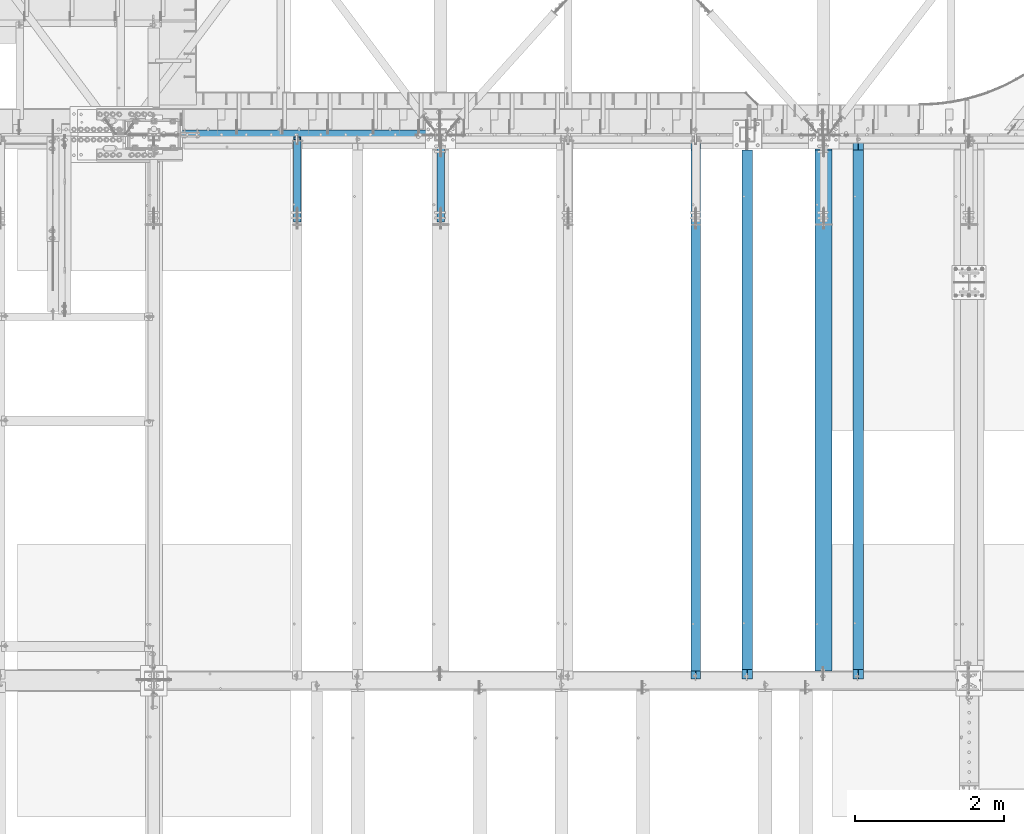
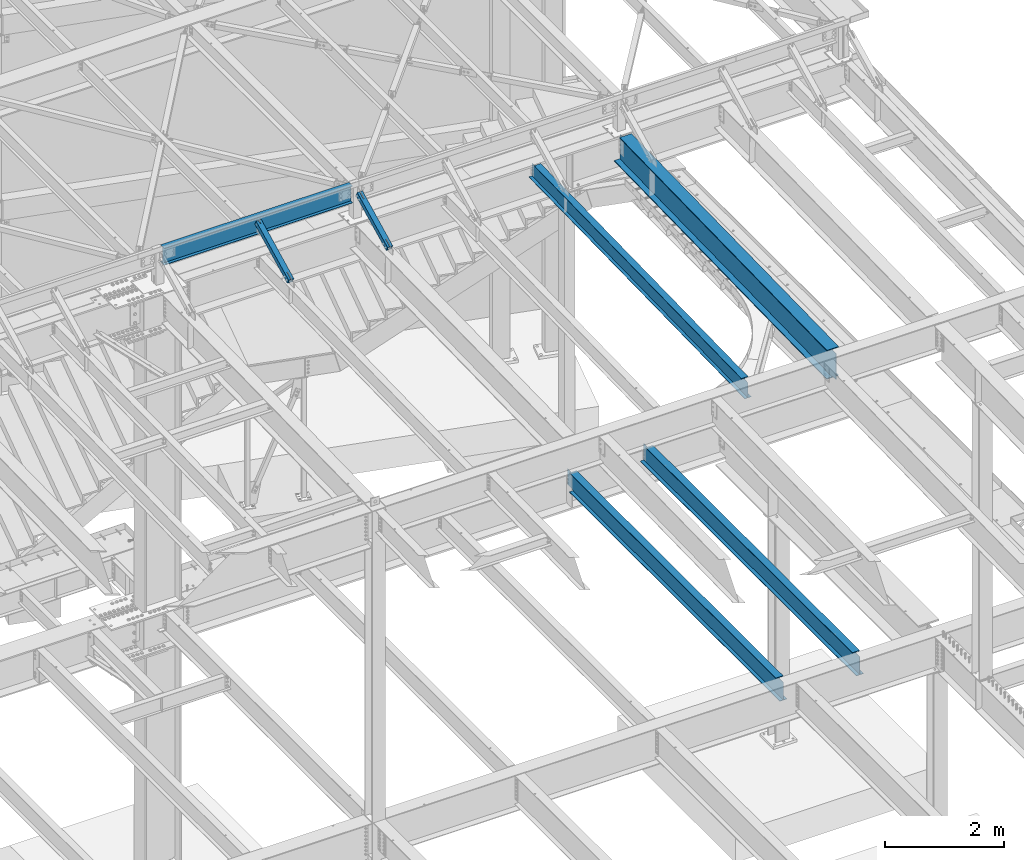
# One storey, part 1161 of 1763: 5 beams, 2 members, 7 elements without a shape of their own.
"""IFC2X3 building model written with IfcOpenShell, lengths in millimetres."""

import ifcopenshell
import ifcopenshell.guid

model = None  # the IFC model being written
_history = None  # IfcOwnerHistory: only IFC2X3 demands one
_inside = {}  # id of a spatial element -> (the spatial element, [elements in it])
_under = {}  # id of a project, library or spatial element -> (it, [spatial elements below it])
_declared = {}  # id of a project -> (the project, [libraries it declares])
_typed = {}  # id of a type object -> (the type object, [elements of that type])
_made_of = {}  # id of a material, layer set ... -> (it, [elements and type objects made of it])


def new_model(schema):
    """Start an empty IFC model of exactly this schema.

    Asked for "IFC4X3", IfcOpenShell would pick the latest addendum, in which some entities
    have other attributes; the version numbers below select the first issue.
    IFC2X3 requires an IfcOwnerHistory on every rooted entity: one is made here for all.
    """
    global model, _history
    if schema == "IFC4X3":
        model = ifcopenshell.file(schema_version=(4, 3, 0, 0))
    else:
        model = ifcopenshell.file(schema=schema)
    _inside.clear()
    _under.clear()
    _declared.clear()
    _typed.clear()
    _made_of.clear()
    _history = None
    if model.schema == "IFC2X3":
        org = make("IfcOrganization", Name="unknown")
        user = make(
            "IfcPersonAndOrganization",
            ThePerson=make("IfcPerson", FamilyName="unknown"),
            TheOrganization=org,
        )
        app = make(
            "IfcApplication",
            ApplicationDeveloper=org,
            Version="unknown",
            ApplicationFullName="unknown",
            ApplicationIdentifier="unknown",
        )
        _history = make(
            "IfcOwnerHistory",
            OwningUser=user,
            OwningApplication=app,
            ChangeAction="ADDED",
            CreationDate=0,
        )
    return model


def make(cls, **values):
    """One entity of the class cls with the attributes given. An attribute that is None is left unset."""
    return model.create_entity(
        cls, **{name: value for name, value in values.items() if value is not None}
    )


def rooted(cls, **values):
    """An entity with a GlobalId (a new one), such as an element, a storey or a relation."""
    return make(cls, GlobalId=ifcopenshell.guid.new(), OwnerHistory=_history, **values)


def si_unit(unit_type, name, prefix=None):
    """IfcSIUnit, for example si_unit("LENGTHUNIT", "METRE", prefix="MILLI")."""
    return make("IfcSIUnit", UnitType=unit_type, Prefix=prefix, Name=name)


def assignment(units):
    """IfcUnitAssignment: the units of a project."""
    return None if units is None else make("IfcUnitAssignment", Units=units)


def point(xyz):
    """IfcCartesianPoint."""
    return None if xyz is None else make("IfcCartesianPoint", Coordinates=xyz)


def direction(xyz):
    """IfcDirection."""
    return None if xyz is None else make("IfcDirection", DirectionRatios=xyz)


def frame(location, z_axis=None, x_axis=None):
    """IfcAxis2Placement3D, a coordinate frame: its origin and axes. An axis left out is left unset."""
    return make(
        "IfcAxis2Placement3D",
        Location=point(location),
        Axis=direction(z_axis),
        RefDirection=direction(x_axis),
    )


def origin_with_axes():
    """The frame at (0, 0, 0) with the z axis (0, 0, 1) and the x axis (1, 0, 0) written out."""
    return frame((0.0, 0.0, 0.0), z_axis=(0.0, 0.0, 1.0), x_axis=(1.0, 0.0, 0.0))


def place(relative_to, where):
    """IfcLocalPlacement: puts the frame where relative to a parent placement (None: the world)."""
    return make(
        "IfcLocalPlacement", PlacementRelTo=relative_to, RelativePlacement=where
    )


def context(
    kind, dimensions, precision=None, world=None, true_north=None, identifier=None
):
    """IfcGeometricRepresentationContext, for example the 3D "Model" context."""
    return make(
        "IfcGeometricRepresentationContext",
        ContextIdentifier=identifier,
        ContextType=kind,
        CoordinateSpaceDimension=dimensions,
        Precision=precision,
        WorldCoordinateSystem=world,
        TrueNorth=true_north,
    )


def subcontext(parent, identifier, kind, view, scale=None):
    """IfcGeometricRepresentationSubContext, for example "Body" below "Model"."""
    return make(
        "IfcGeometricRepresentationSubContext",
        ContextIdentifier=identifier,
        ContextType=kind,
        ParentContext=parent,
        TargetScale=scale,
        TargetView=view,
    )


def project(units=None, contexts=None):
    """IfcProject with its units and contexts."""
    return rooted(
        "IfcProject",
        Name="project",
        RepresentationContexts=contexts,
        UnitsInContext=assignment(units),
    )


def spatial(cls, under=None, at=None, **own):
    """A site, building, storey or space (cls), placed at a placement, below another one or the project."""
    s = rooted(cls, ObjectPlacement=at, **own)
    if under is not None:
        _under.setdefault(under.id(), (under, []))[1].append(s)
    return s


def faces_of(points, faces, orient=None, outer=None):
    """IfcFace entities. A face is a list of loops; a loop is a list of indices into points, from 0.

    orient and outer hold one flag for each loop. By default every Orientation is true, the
    first loop of a face is its IfcFaceOuterBound and the others are IfcFaceBound.
    """
    made = []
    for i, loops in enumerate(faces):
        bounds = []
        for j, loop in enumerate(loops):
            is_outer = j == 0 if outer is None else outer[i][j]
            bounds.append(
                make(
                    "IfcFaceOuterBound" if is_outer else "IfcFaceBound",
                    Bound=make("IfcPolyLoop", Polygon=[points[k] for k in loop]),
                    Orientation=True if orient is None else orient[i][j],
                )
            )
        made.append(make("IfcFace", Bounds=bounds))
    return made


def faceted_brep(points, faces, orient=None, outer=None, voids=None):
    """IfcFacetedBrep: a solid bounded by flat faces; with voids (closed shells), ...WithVoids."""
    shared = [point(p) for p in points]
    hull = make("IfcClosedShell", CfsFaces=faces_of(shared, faces, orient, outer))
    if voids is None:
        return make("IfcFacetedBrep", Outer=hull)
    return make(
        "IfcFacetedBrepWithVoids",
        Outer=hull,
        Voids=[
            make(cls, CfsFaces=faces_of(shared, fs, o, b)) for cls, fs, o, b in voids
        ],
    )


def shape(context_of_items, identifier, shape_type, items):
    """IfcShapeRepresentation: the items that make up one representation, for example the "Body"."""
    return make(
        "IfcShapeRepresentation",
        ContextOfItems=context_of_items,
        RepresentationIdentifier=identifier,
        RepresentationType=shape_type,
        Items=items,
    )


def material(Name=None, Category=None):
    """IfcMaterial."""
    return make("IfcMaterial", Name=Name, Category=Category)


def made_of(thing, what):
    """Note that an element or type object is made of a material, layer set ...; save() writes the relation."""
    if what is not None:
        _made_of.setdefault(what.id(), (what, []))[1].append(thing)
    return thing


def type_object(cls, material=None, **own):
    """A type object (cls), such as IfcWallType, which elements share."""
    return made_of(rooted(cls, **own), material)


def element(
    cls,
    number,
    at=None,
    inside=None,
    cuts=None,
    type_object=None,
    material=None,
    context=None,
    identifier="Body",
    shape_type=None,
    held_by="IfcProductDefinitionShape",
    body=None,
    shapes=None,
    **own,
):
    """One element of the class cls, such as IfcWall. Its Tag is "e" and its number.

    at: its placement. inside: the storey or other place that contains it. cuts: it is an
    opening in that element (IfcRelVoidsElement). A single representation is given by context,
    identifier, shape_type and body (its items); several are given by shapes. held_by: the class
    of the entity that holds the representations. save() writes the other relations.
    """
    e = rooted(cls, Tag="e%d" % number, ObjectPlacement=at, **own)
    if body is not None:
        shapes = [shape(context, identifier, shape_type, body)]
    if shapes is not None:
        e.Representation = make(held_by, Representations=shapes)
    if inside is not None:
        _inside.setdefault(inside.id(), (inside, []))[1].append(e)
    if cuts is not None:
        rooted(
            "IfcRelVoidsElement", RelatingBuildingElement=cuts, RelatedOpeningElement=e
        )
    if type_object is not None:
        _typed.setdefault(type_object.id(), (type_object, []))[1].append(e)
    return made_of(e, material)


def aggregate(whole, parts):
    """IfcRelAggregates: a whole, such as a stair, and the parts it consists of."""
    return rooted("IfcRelAggregates", RelatingObject=whole, RelatedObjects=parts)


def save(model, path):
    """Write the relations noted so far, then the file.

    IfcRelAggregates (storeys below a building ...), IfcRelContainedInSpatialStructure (elements
    in a storey), IfcRelDefinesByType, IfcRelAssociatesMaterial and IfcRelDeclares: one each for
    every whole, place, type object, material and project.
    """
    for whole, parts in _under.values():
        aggregate(whole, parts)
    for where, things in _inside.values():
        rooted(
            "IfcRelContainedInSpatialStructure",
            RelatedElements=things,
            RelatingStructure=where,
        )
    for kind, things in _typed.values():
        rooted("IfcRelDefinesByType", RelatedObjects=things, RelatingType=kind)
    for what, things in _made_of.values():
        rooted("IfcRelAssociatesMaterial", RelatedObjects=things, RelatingMaterial=what)
    for by, libraries in _declared.values():
        rooted("IfcRelDeclares", RelatingContext=by, RelatedDefinitions=libraries)
    model.write(path)


model = new_model("IFC2X3")

# Units and contexts
model_context = context("Model", 3, precision=1e-05, world=origin_with_axes())
body_context = subcontext(model_context, "Body", "Model", "MODEL_VIEW")
ifc_project = project(units=[si_unit("LENGTHUNIT", "METRE", prefix="MILLI"), si_unit("AREAUNIT", "SQUARE_METRE"), si_unit("VOLUMEUNIT", "CUBIC_METRE"), si_unit("MASSUNIT", "GRAM", prefix="KILO"), si_unit("TIMEUNIT", "SECOND"), si_unit("PLANEANGLEUNIT", "RADIAN"), si_unit("SOLIDANGLEUNIT", "STERADIAN"), si_unit("THERMODYNAMICTEMPERATUREUNIT", "DEGREE_CELSIUS"), si_unit("LUMINOUSINTENSITYUNIT", "LUMEN")], contexts=[model_context])

# Site, building, storey
site_placement = place(None, origin_with_axes())
site = spatial("IfcSite", under=ifc_project, at=site_placement, CompositionType="ELEMENT")
building_placement = place(site_placement, origin_with_axes())
building = spatial("IfcBuilding", under=site, at=building_placement, Name="Undefined", CompositionType="ELEMENT")
storey_placement = place(building_placement, origin_with_axes())
storey = spatial("IfcBuildingStorey", under=building, at=storey_placement, Name="Undefined", CompositionType="ELEMENT", Elevation=0.0)

# Assembly, member
assembly_1_placement = place(storey_placement, origin_with_axes())
assembly_1 = element("IfcElementAssembly", 1, at=assembly_1_placement, inside=storey, Name="BEAM", AssemblyPlace="NOTDEFINED", PredefinedType="RIGID_FRAME")
ifc_material_1 = material()
member_type = type_object("IfcMemberType", Name="HSS4X4X1/2", PredefinedType="NOTDEFINED")
member_1_placement = place(assembly_1_placement, frame((-33032.1372736984, 50822.4762411269, 11720.6381213765), z_axis=(-1.0, 0.0, 0.0), x_axis=(0.0, 0.894427191199916, 0.447213595099959)))
member_1 = element("IfcMember", 2, at=member_1_placement, type_object=member_type, material=ifc_material_1, Name="BEAM", ObjectType="HSS4X4X1/2", context=body_context, shape_type="Brep", body=[
    faceted_brep([(1394.22226894295, -50.8000000020184, -7.9375), (1394.2222689429, -38.1000000020122, -7.9375), (1321.53025774739, -38.1000000019103, -7.9375), (1327.88025774027, -50.8000000019219, -7.9375), (1321.53025774739, -38.1000000019103, 7.9375), (1327.88025774027, -50.8000000019219, 7.9375), (1394.22226894295, -50.8000000020184, 7.9375), (1394.2222689429, -38.1000000020122, 7.9375), (1394.22226894266, 38.0999999980304, -7.9375), (1394.22226894262, 50.799999998042, -7.9375), (1277.08025779721, 50.7999999982076, -7.9375), (1283.4302577901, 38.0999999981887, -7.9375), (1277.08025779721, 50.7999999982076, 7.9375), (1283.4302577901, 38.0999999981887, 7.9375), (1394.22226894266, 38.0999999980304, 7.9375), (1394.22226894262, 50.799999998042, 7.9375), (166.342448712407, -38.100000000255, 38.0999999999985), (166.342448712276, 38.0999999997875, 38.0999999999985), (1394.22226894266, 38.0999999980304, 38.0999999999985), (1394.2222689429, -38.1000000020122, 38.0999999999985), (1394.2222689429, -38.1000000020122, -38.0999999999985), (166.342448712407, -38.100000000255, -38.0999999999985), (166.342448712407, -38.100000000255, -7.93749999974898), (317.154945941751, -38.1000000004715, -7.93749999987267), (320.192495686126, -38.1000000004769, -7.33329378918279), (322.767606017376, -38.1000000004806, -5.61266007554514), (324.488239731007, -38.1000000004842, -3.03754974427284), (325.092445941693, -38.1000000004842, 2.5465851649642e-10), (324.488239731007, -38.1000000004842, 3.03754974465119), (322.767606017376, -38.1000000004806, 5.61266007592349), (320.192495686126, -38.1000000004788, 7.33329378956478), (317.154945941751, -38.1000000004733, 7.93750000025466), (166.342448712407, -38.100000000255, 7.93750000025466), (166.342448712276, 38.0999999997875, -38.0999999999985), (1394.22226894266, 38.0999999980304, -38.0999999999985), (166.342448712276, 38.0999999997875, 7.93750000025466), (166.342448712254, 50.7999999997955, 7.93750000025466), (317.154945941591, 50.7999999995791, 7.93750000025466), (317.15494594162, 38.0999999995711, 7.93750000025466), (320.192495685966, 50.7999999995736, 7.33329378956478), (320.192495685995, 38.0999999995693, 7.33329378956478), (322.767606017216, 50.7999999995718, 5.61266007592349), (322.767606017245, 38.0999999995638, 5.61266007592349), (324.488239730847, 50.7999999995682, 3.03754974465119), (324.488239730868, 38.0999999995638, 3.03754974465119), (325.092445941533, 50.7999999995682, 2.5465851649642e-10), (325.092445941555, 38.0999999995583, 2.5465851649642e-10), (324.488239730847, 50.7999999995682, -3.03754974427284), (324.488239730861, 38.0999999995602, -3.03754974427284), (322.767606017209, 50.79999999957, -5.61266007554514), (322.767606017245, 38.0999999995638, -5.61266007554514), (320.192495685966, 50.7999999995754, -7.33329378918279), (320.19249568598, 38.0999999995674, -7.33329378918279), (317.154945941591, 50.7999999995791, -7.93749999987267), (317.154945941606, 38.0999999995693, -7.93749999987267), (166.342448712254, 50.7999999997955, -7.93749999974898), (166.342448712276, 38.0999999997875, -7.93749999974898), (166.342448712254, 50.7999999997955, -50.7999999999993), (166.342448712421, -50.8000000002612, -50.7999999999993), (166.342448712421, -50.8000000002612, -7.93749999974898), (317.154945941773, -50.8000000004795, -7.93749999987267), (320.192495686155, -50.8000000004831, -7.33329378918279), (322.767606017391, -50.8000000004868, -5.61266007554514), (324.488239731028, -50.800000000494, -3.03754974427284), (325.092445941715, -50.8000000004904, 2.5465851649642e-10), (324.488239731028, -50.800000000494, 3.03754974465119), (322.767606017405, -50.8000000004849, 5.61266007592349), (320.192495686155, -50.8000000004849, 7.33329378956478), (317.154945941787, -50.8000000004795, 7.93750000025466), (166.342448712421, -50.8000000002612, 7.93750000025466), (166.342448712421, -50.8000000002612, 50.7999999999993), (166.342448712254, 50.7999999997955, 50.7999999999993), (1394.22226894295, -50.8000000020184, 50.7999999999993), (1394.22226894262, 50.799999998042, 50.7999999999993), (1394.22226894262, 50.799999998042, -50.7999999999993), (1394.22226894295, -50.8000000020184, -50.7999999999993)], [[[0, 1, 2, 3]], [[3, 2, 4, 5]], [[6, 5, 4, 7]], [[8, 9, 10, 11]], [[11, 10, 12, 13]], [[14, 13, 12, 15]], [[16, 17, 18, 19]], [[2, 1, 20, 21, 22, 23, 24, 25, 26, 27, 28, 29, 30, 31, 32, 16, 19, 7, 4]], [[33, 21, 20, 34]], [[35, 36, 37, 38]], [[38, 37, 39, 40]], [[40, 39, 41, 42]], [[42, 41, 43, 44]], [[44, 43, 45, 46]], [[46, 45, 47, 48]], [[48, 47, 49, 50]], [[50, 49, 51, 52]], [[52, 51, 53, 54]], [[54, 53, 55, 56]], [[21, 33, 56, 55, 57, 58, 59, 22]], [[60, 23, 22, 59]], [[61, 24, 23, 60]], [[62, 25, 24, 61]], [[63, 26, 25, 62]], [[64, 27, 26, 63]], [[65, 28, 27, 64]], [[66, 29, 28, 65]], [[67, 30, 29, 66]], [[68, 31, 30, 67]], [[69, 32, 31, 68]], [[70, 71, 36, 35, 17, 16, 32, 69]], [[71, 70, 72, 73]], [[19, 18, 14, 15, 73, 72, 6, 7]], [[10, 9, 74, 57, 55, 53, 51, 49, 47, 45, 43, 41, 39, 37, 36, 71, 73, 15, 12]], [[58, 57, 74, 75]], [[72, 70, 69, 68, 67, 66, 65, 64, 63, 62, 61, 60, 59, 58, 75, 0, 3, 5, 6]], [[75, 74, 9, 8, 34, 20, 1, 0]], [[18, 17, 35, 38, 40, 42, 44, 46, 48, 50, 52, 54, 56, 33, 34, 8, 11, 13, 14]]]),
])
aggregate(assembly_1, [member_1])

assembly_2_placement = place(storey_placement, origin_with_axes())
assembly_2 = element("IfcElementAssembly", 3, at=assembly_2_placement, inside=storey, Name="BEAM", AssemblyPlace="NOTDEFINED", PredefinedType="RIGID_FRAME")
member_2_placement = place(assembly_2_placement, frame((-31109.3096174484, 50822.4448748991, 11720.6374724137), z_axis=(-1.0, 0.0, 0.0), x_axis=(0.0, 0.894427191199916, 0.447213595099959)))
member_2 = element("IfcMember", 4, at=member_2_placement, type_object=member_type, material=ifc_material_1, Name="BEAM", ObjectType="HSS4X4X1/2", context=body_context, shape_type="Brep", body=[
    faceted_brep([(1312.61289971653, -50.8000000018983, -7.9375), (1312.61289971651, -38.1000000018903, -7.9375), (1161.80039971038, -38.1000000016793, -7.9375), (1161.8003997104, -50.8000000016891, -7.9375), (1158.762849966, -38.1000000016738, -7.33329378931012), (1158.76284996603, -50.8000000016782, -7.33329378931012), (1156.18773963476, -38.1000000016684, -5.61266007566883), (1156.18773963477, -50.8000000016764, -5.61266007566883), (1154.46710592113, -38.1000000016629, -3.03754974439653), (1154.46710592115, -50.8000000016727, -3.03754974439653), (1153.86289971044, -38.1000000016684, 0.0), (1153.86289971046, -50.8000000016746, 0.0), (1154.46710592113, -38.1000000016629, 3.03754974439653), (1154.46710592115, -50.8000000016727, 3.03754974439653), (1156.18773963476, -38.1000000016684, 5.61266007566883), (1156.18773963477, -50.8000000016764, 5.61266007566883), (1158.762849966, -38.1000000016738, 7.33329378931012), (1158.76284996603, -50.8000000016782, 7.33329378931012), (1161.80039971038, -38.1000000016793, 7.9375), (1161.8003997104, -50.8000000016891, 7.9375), (1312.61289971653, -50.8000000018983, 7.9375), (1312.61289971651, -38.1000000018903, 7.9375), (1312.61289971639, 38.0999999981505, -7.9375), (1312.61289971636, 50.7999999981585, -7.9375), (1161.80039971021, 50.7999999983731, -7.9375), (1161.80039971024, 38.0999999983687, -7.9375), (1158.76284996585, 50.7999999983786, -7.33329378931012), (1158.76284996586, 38.0999999983705, -7.33329378931012), (1156.18773963459, 50.7999999983804, -5.61266007566883), (1156.18773963462, 38.099999998376, -5.61266007566883), (1154.46710592096, 50.7999999983858, -3.03754974439653), (1154.46710592099, 38.0999999983778, -3.03754974439653), (1153.86289971027, 50.7999999983858, 0.0), (1153.86289971031, 38.0999999983796, 0.0), (1154.46710592096, 50.7999999983858, 3.03754974439653), (1154.46710592099, 38.0999999983778, 3.03754974439653), (1156.18773963459, 50.7999999983804, 5.61266007566883), (1156.18773963462, 38.099999998376, 5.61266007566883), (1158.76284996585, 50.7999999983786, 7.33329378931012), (1158.76284996586, 38.0999999983705, 7.33329378931012), (1161.80039971021, 50.7999999983731, 7.9375), (1161.80039971024, 38.0999999983687, 7.9375), (1312.61289971639, 38.0999999981505, 7.9375), (1312.61289971636, 50.7999999981585, 7.9375), (166.342448712407, -38.100000000255, 38.0999999999985), (166.342448712276, 38.0999999997875, 38.0999999999985), (1312.61289971639, 38.0999999981505, 38.0999999999985), (1312.61289971651, -38.1000000018903, 38.0999999999985), (322.767606017376, -38.1000000004806, 5.61266007592349), (320.192495686126, -38.1000000004788, 7.33329378956478), (317.154945941751, -38.1000000004733, 7.93750000025466), (166.342448712407, -38.100000000255, 7.93750000025466), (1312.61289971651, -38.1000000018903, -38.0999999999985), (166.342448712407, -38.100000000255, -38.0999999999985), (166.342448712407, -38.100000000255, -7.93749999974898), (317.154945941751, -38.1000000004715, -7.93749999987267), (320.192495686126, -38.1000000004769, -7.33329378918279), (322.767606017376, -38.1000000004806, -5.61266007554514), (324.488239731007, -38.1000000004842, -3.03754974427284), (325.092445941693, -38.1000000004842, 2.5465851649642e-10), (324.488239731007, -38.1000000004842, 3.03754974465119), (166.342448712276, 38.0999999997875, -38.0999999999985), (1312.61289971639, 38.0999999981505, -38.0999999999985), (166.342448712276, 38.0999999997875, 7.93750000025466), (166.342448712254, 50.7999999997955, 7.93750000025466), (317.154945941591, 50.7999999995791, 7.93750000025466), (317.15494594162, 38.0999999995711, 7.93750000025466), (320.192495685966, 50.7999999995736, 7.33329378956478), (320.192495685995, 38.0999999995693, 7.33329378956478), (322.767606017216, 50.7999999995718, 5.61266007592349), (322.767606017245, 38.0999999995638, 5.61266007592349), (324.488239730847, 50.7999999995682, 3.03754974465119), (324.488239730868, 38.0999999995638, 3.03754974465119), (325.092445941533, 50.7999999995682, 2.5465851649642e-10), (325.092445941555, 38.0999999995583, 2.5465851649642e-10), (324.488239730847, 50.7999999995682, -3.03754974427284), (324.488239730861, 38.0999999995602, -3.03754974427284), (322.767606017209, 50.79999999957, -5.61266007554514), (322.767606017245, 38.0999999995638, -5.61266007554514), (320.192495685966, 50.7999999995754, -7.33329378918279), (320.19249568598, 38.0999999995674, -7.33329378918279), (317.154945941591, 50.7999999995791, -7.93749999987267), (317.154945941606, 38.0999999995693, -7.93749999987267), (166.342448712254, 50.7999999997955, -7.93749999974898), (166.342448712276, 38.0999999997875, -7.93749999974898), (166.342448712254, 50.7999999997955, -50.7999999999993), (166.342448712421, -50.8000000002612, -50.7999999999993), (166.342448712421, -50.8000000002612, -7.93749999974898), (317.154945941773, -50.8000000004795, -7.93749999987267), (320.192495686155, -50.8000000004831, -7.33329378918279), (322.767606017391, -50.8000000004868, -5.61266007554514), (324.488239731028, -50.800000000494, -3.03754974427284), (325.092445941715, -50.8000000004904, 2.5465851649642e-10), (324.488239731028, -50.800000000494, 3.03754974465119), (322.767606017405, -50.8000000004849, 5.61266007592349), (320.192495686155, -50.8000000004849, 7.33329378956478), (317.154945941787, -50.8000000004795, 7.93750000025466), (166.342448712421, -50.8000000002612, 7.93750000025466), (166.342448712421, -50.8000000002612, 50.7999999999993), (166.342448712254, 50.7999999997955, 50.7999999999993), (1312.61289971653, -50.8000000018983, 50.7999999999993), (1312.61289971636, 50.7999999981585, 50.7999999999993), (1312.61289971636, 50.7999999981585, -50.7999999999993), (1312.61289971653, -50.8000000018983, -50.7999999999993)], [[[0, 1, 2, 3]], [[3, 2, 4, 5]], [[5, 4, 6, 7]], [[7, 6, 8, 9]], [[9, 8, 10, 11]], [[11, 10, 12, 13]], [[13, 12, 14, 15]], [[15, 14, 16, 17]], [[17, 16, 18, 19]], [[20, 19, 18, 21]], [[22, 23, 24, 25]], [[25, 24, 26, 27]], [[27, 26, 28, 29]], [[29, 28, 30, 31]], [[31, 30, 32, 33]], [[33, 32, 34, 35]], [[35, 34, 36, 37]], [[37, 36, 38, 39]], [[39, 38, 40, 41]], [[42, 41, 40, 43]], [[44, 45, 46, 47]], [[48, 49, 50, 51, 44, 47, 21, 18, 16, 14, 12, 10, 8, 6, 4, 2, 1, 52, 53, 54, 55, 56, 57, 58, 59, 60]], [[61, 53, 52, 62]], [[63, 64, 65, 66]], [[66, 65, 67, 68]], [[68, 67, 69, 70]], [[70, 69, 71, 72]], [[72, 71, 73, 74]], [[74, 73, 75, 76]], [[76, 75, 77, 78]], [[78, 77, 79, 80]], [[80, 79, 81, 82]], [[82, 81, 83, 84]], [[53, 61, 84, 83, 85, 86, 87, 54]], [[88, 55, 54, 87]], [[89, 56, 55, 88]], [[90, 57, 56, 89]], [[91, 58, 57, 90]], [[92, 59, 58, 91]], [[93, 60, 59, 92]], [[94, 48, 60, 93]], [[95, 49, 48, 94]], [[96, 50, 49, 95]], [[97, 51, 50, 96]], [[98, 99, 64, 63, 45, 44, 51, 97]], [[99, 98, 100, 101]], [[47, 46, 42, 43, 101, 100, 20, 21]], [[69, 67, 65, 64, 99, 101, 43, 40, 38, 36, 34, 32, 30, 28, 26, 24, 23, 102, 85, 83, 81, 79, 77, 75, 73, 71]], [[86, 85, 102, 103]], [[90, 89, 88, 87, 86, 103, 0, 3, 5, 7, 9, 11, 13, 15, 17, 19, 20, 100, 98, 97, 96, 95, 94, 93, 92, 91]], [[103, 102, 23, 22, 62, 52, 1, 0]], [[78, 80, 82, 84, 61, 62, 22, 25, 27, 29, 31, 33, 35, 37, 39, 41, 42, 46, 45, 63, 66, 68, 70, 72, 74, 76]]]),
])
aggregate(assembly_2, [member_2])

# Assembly, beam
assembly_3_placement = place(storey_placement, origin_with_axes())
assembly_3 = element("IfcElementAssembly", 5, at=assembly_3_placement, inside=storey, Name="BEAM", AssemblyPlace="NOTDEFINED", PredefinedType="RIGID_FRAME")
ifc_material_2 = material(Name="STEEL/A992")
beam_type_1 = type_object("IfcBeamType", Name="W14X22", PredefinedType="NOTDEFINED")
beam_1_placement = place(assembly_3_placement, frame((-34949.837273697, 52120.7999998787, 12271.375), z_axis=(0.0, 0.0, 1.0), x_axis=(1.0, 0.0, 0.0)))
beam_1 = element("IfcBeam", 6, at=beam_1_placement, type_object=beam_type_1, material=ifc_material_2, Name="BEAM", ObjectType="W14X22", context=body_context, shape_type="Brep", body=[
    faceted_brep([(88.8999999999942, 63.5, -174.625), (88.8999999999942, 63.5, -166.6875), (3751.62265624343, 63.5, -166.6875), (3751.62265624343, 63.5, -174.625), (88.8999999999942, 3.17500000000291, -166.6875), (3751.62265624343, 3.17500000000291, -166.6875), (88.8999999999942, 3.17500000000291, 166.6875), (3751.62265624343, 3.17500000000291, 166.6875), (88.8999999999942, 63.5, 166.6875), (3751.62265624343, 63.5, 166.6875), (88.8999999999942, 63.5, 174.625), (3751.62265624343, 63.5, 174.625), (88.8999999999942, -63.5, 174.625), (3751.62265624343, -63.5, 174.625), (88.8999999999942, -63.5, 166.6875), (3751.62265624343, -63.5, 166.6875), (88.8999999999942, -3.17500000000291, 166.6875), (3751.62265624343, -3.17500000000291, 166.6875), (88.8999999999942, -3.17500000000291, -166.6875), (3751.62265624343, -3.17500000000291, -166.6875), (88.8999999999942, -63.5, -166.6875), (3751.62265624343, -63.5, -166.6875), (88.8999999999942, -63.5, -174.625), (3751.62265624343, -63.5, -174.625)], [[[0, 1, 2, 3]], [[1, 4, 5, 2]], [[4, 6, 7, 5]], [[6, 8, 9, 7]], [[8, 10, 11, 9]], [[10, 12, 13, 11]], [[12, 14, 15, 13]], [[14, 16, 17, 15]], [[16, 18, 19, 17]], [[18, 20, 21, 19]], [[20, 22, 23, 21]], [[22, 0, 3, 23]], [[5, 7, 9, 11, 13, 15, 17, 19, 21, 23, 3, 2]], [[22, 20, 18, 16, 14, 12, 10, 8, 6, 4, 1, 0]]]),
])
aggregate(assembly_3, [beam_1])

assembly_4_placement = place(storey_placement, origin_with_axes())
assembly_4 = element("IfcElementAssembly", 7, at=assembly_4_placement, inside=storey, Name="BEAM", AssemblyPlace="NOTDEFINED", PredefinedType="RIGID_FRAME")
beam_2_placement = place(assembly_4_placement, frame((-27687.5096174484, 44809.2121579122, 11421.5633921212), z_axis=(0.0, -0.0206852279954837, 0.999786037781472), x_axis=(0.0, 0.999786037781472, 0.0206852279954825)))
beam_2 = element("IfcBeam", 8, at=beam_2_placement, type_object=beam_type_1, material=ifc_material_2, Name="BEAM", ObjectType="W14X22", context=body_context, shape_type="Brep", body=[
    faceted_brep([(116.24722620719, -3.17499999999927, 136.265001678286), (116.24722620719, 3.17499999999927, 136.265001678286), (17.4665018602245, 3.17499999999927, 136.265001678306), (17.4665018602245, -3.17499999999927, 136.265001678306), (121.10730572528, -3.17499999999927, 137.231731600872), (121.10730572528, 3.17499999999927, 137.231731600872), (125.227482193462, -3.17499999999927, 139.984745501344), (125.227482193462, 3.17499999999927, 139.984745501344), (127.980496093973, -3.17499999999927, 144.104921969487), (127.980496093973, 3.17499999999927, 144.104921969487), (128.947226016564, -3.17499999999927, 148.965001487522), (128.947226016564, 3.17499999999927, 148.965001487522), (128.947226016564, -63.5, 174.624999999836), (128.947226016564, 63.5, 174.624999999836), (128.947226016571, 63.5, 166.687499999842), (128.947226016571, 3.17499999999927, 166.687499999842), (128.947226016571, -3.17499999999927, 166.687499999842), (128.947226016571, -63.5, 166.687499999842), (11.1985191797066, -3.17499999999927, -166.687499999876), (11.1985191797066, -63.5, -166.687499999876), (7286.68019766203, -63.5, -166.687500001812), (7286.68019766203, -3.17499999999927, -166.687500001812), (11.0342950447375, -63.5, -174.624999999869), (7286.51597352705, -63.5, -174.625000001804), (11.0342950447375, 63.5, -174.624999999869), (7286.51597352705, 63.5, -174.625000001804), (11.1985191797066, 63.5, -166.687499999876), (7286.68019766203, 63.5, -166.687500001812), (11.1985191797066, 3.17499999999927, -166.687499999876), (7286.68019766203, 3.17499999999927, -166.687500001812), (7292.02852510755, 3.17499999999927, 91.8149978515976), (7292.02852510755, -3.17499999999927, 91.8149978515976), (7125.028904344, 3.17499999999927, 91.8149978516285), (7125.028904344, -3.17499999999927, 91.8149978516285), (7120.16882482591, 3.17499999999927, 92.7817277742161), (7120.16882482591, -3.17499999999927, 92.7817277742161), (7116.04864835773, 3.17499999999927, 95.5347416746881), (7116.04864835773, -3.17499999999927, 95.5347416746881), (7113.29563445722, 3.17499999999927, 99.6549181428345), (7113.29563445722, -3.17499999999927, 99.6549181428345), (7112.32890453462, 3.17499999999927, 104.51499766087), (7112.32890453462, -3.17499999999927, 104.51499766087), (7112.32890453463, -63.5, 174.624999997979), (7112.32890453462, -63.5, 166.687499997985), (7112.32890453462, -3.17499999999927, 166.687499997985), (7112.32890453462, 3.17499999999927, 166.687499997985), (7112.32890453462, 63.5, 166.687499997985), (7112.32890453463, 63.5, 174.624999997979)], [[[0, 1, 2, 3]], [[4, 5, 1, 0]], [[6, 7, 5, 4]], [[8, 9, 7, 6]], [[10, 11, 9, 8]], [[12, 13, 14, 15, 11, 10, 16, 17]], [[18, 19, 20, 21]], [[19, 22, 23, 20]], [[22, 24, 25, 23]], [[24, 26, 27, 25]], [[26, 28, 29, 27]], [[21, 20, 23, 25, 27, 29, 30, 31]], [[31, 30, 32, 33]], [[33, 32, 34, 35]], [[35, 34, 36, 37]], [[37, 36, 38, 39]], [[39, 38, 40, 41]], [[42, 43, 44, 41, 40, 45, 46, 47]], [[43, 42, 12, 17]], [[44, 43, 17, 16]], [[8, 6, 4, 0, 3, 18, 21, 31, 33, 35, 37, 39, 41, 44, 16, 10]], [[28, 26, 24, 22, 19, 18, 3, 2]], [[45, 40, 38, 36, 34, 32, 30, 29, 28, 2, 1, 5, 7, 9, 11, 15]], [[46, 45, 15, 14]], [[47, 46, 14, 13]], [[42, 47, 13, 12]]]),
])
aggregate(assembly_4, [beam_2])

assembly_5_placement = place(storey_placement, origin_with_axes())
assembly_5 = element("IfcElementAssembly", 9, at=assembly_5_placement, inside=storey, Name="BEAM", AssemblyPlace="NOTDEFINED", PredefinedType="RIGID_FRAME")
beam_type_2 = type_object("IfcBeamType", Name="W24X76", PredefinedType="NOTDEFINED")
beam_3_placement = place(assembly_5_placement, frame((-25976.6096174484, 44811.8720196671, 11293.0034049879), z_axis=(0.0, -0.0206852279954837, 0.999786037781472), x_axis=(0.0, 0.999786037781472, 0.0206852279954825)))
beam_3 = element("IfcBeam", 10, at=beam_3_placement, type_object=beam_type_2, material=ifc_material_2, Name="BEAM", ObjectType="W24X76", context=body_context, shape_type="Brep", body=[
    faceted_brep([(6.49632960907184, -5.55625000000146, -265.372499999168), (6.49632960907184, 5.55625000000146, -265.372499999168), (113.586795220392, 5.55625000000146, -265.372499999228), (113.586795220392, -5.55625000000146, -265.372499999228), (118.446874738482, 5.55625000000146, -266.339229921816), (118.446874738482, -5.55625000000146, -266.339229921816), (122.567051206664, 5.55625000000146, -269.092243822288), (122.567051206664, -5.55625000000146, -269.092243822288), (125.32006510716, 5.55625000000146, -273.212420290434), (125.32006510716, -5.55625000000146, -273.212420290434), (126.286795029759, -5.55625000000146, -278.07249980847), (126.286795029759, 5.55625000000146, -278.07249980847), (126.286795029759, 5.55625000000146, -285.749999999816), (126.286795029759, 114.299999999999, -285.749999999816), (126.286795029751, 114.299999999999, -303.212499999803), (126.286795029751, -114.299999999999, -303.212499999803), (126.286795029759, -114.299999999999, -285.749999999816), (126.286795029759, -5.55625000000146, -285.749999999816), (126.286795029817, 5.55625000000146, 285.749999999754), (126.286795029817, 114.299999999999, 285.749999999754), (7109.66847354787, 114.299999999999, 285.749999997897), (7109.66847354787, 5.55625000000146, 285.749999997897), (113.58679522045, -5.55625000000146, 264.852501677899), (113.58679522045, 5.55625000000146, 264.852501677899), (17.4665018600936, 5.55625000000146, 264.852501677915), (17.4665018600936, -5.55625000000146, 264.852501677915), (118.446874738533, -5.55625000000146, 265.819231600481), (118.446874738533, 5.55625000000146, 265.819231600481), (122.567051206723, -5.55625000000146, 268.572245500953), (122.567051206723, 5.55625000000146, 268.572245500953), (125.320065107226, -5.55625000000146, 272.692421969095), (125.320065107226, 5.55625000000146, 272.692421969095), (126.286795029824, -5.55625000000146, 277.552501487131), (126.286795029824, 5.55625000000146, 277.552501487131), (126.286795029817, -114.299999999999, 303.212499999741), (126.286795029817, 114.299999999999, 303.212499999741), (126.286795029817, -5.55625000000146, 285.749999999754), (126.286795029817, -114.299999999999, 285.749999999754), (7109.66847354787, -5.55625000000146, 285.749999997897), (7109.66847354787, -114.299999999999, 285.749999997897), (7109.66847354788, -114.299999999999, 303.212499997884), (7109.66847354788, 114.299999999999, 303.212499997884), (7109.66847354787, -5.55625000000146, 233.102497660489), (7109.66847354787, 5.55625000000146, 233.102497660489), (7110.63520347048, -5.55625000000146, 228.242418142454), (7110.63520347048, 5.55625000000146, 228.242418142454), (7113.38821737097, -5.55625000000146, 224.122241674309), (7113.38821737097, 5.55625000000146, 224.122241674309), (7117.50839383915, -5.55625000000146, 221.369227773837), (7117.50839383915, 5.55625000000146, 221.369227773837), (7122.36847335724, -5.55625000000146, 220.402497851248), (7122.36847335724, 5.55625000000146, 220.402497851248), (7292.02852510743, -5.55625000000146, 220.402497851217), (7292.02852510743, 5.55625000000146, 220.402497851217), (7281.55640465069, -5.55625000000146, -285.750000001717), (7281.55640465069, -114.299999999999, -285.750000001717), (7281.19511155374, -114.299999999999, -303.212500001704), (7281.19511155374, 114.299999999999, -303.212500001704), (7281.55640465069, 114.299999999999, -285.750000001717), (7281.55640465069, 5.55625000000146, -285.750000001717)], [[[0, 1, 2, 3]], [[3, 2, 4, 5]], [[5, 4, 6, 7]], [[7, 6, 8, 9]], [[10, 11, 12, 13, 14, 15, 16, 17]], [[9, 8, 11, 10]], [[18, 19, 20, 21]], [[22, 23, 24, 25]], [[26, 27, 23, 22]], [[28, 29, 27, 26]], [[30, 31, 29, 28]], [[32, 33, 31, 30]], [[34, 35, 19, 18, 33, 32, 36, 37]], [[37, 36, 38, 39]], [[34, 37, 39, 40]], [[35, 34, 40, 41]], [[19, 35, 41, 20]], [[40, 39, 38, 42, 43, 21, 20, 41]], [[44, 45, 43, 42]], [[46, 47, 45, 44]], [[48, 49, 47, 46]], [[50, 51, 49, 48]], [[52, 53, 51, 50]], [[54, 55, 56, 57, 58, 59, 53, 52]], [[55, 54, 17, 16]], [[56, 55, 16, 15]], [[57, 56, 15, 14]], [[58, 57, 14, 13]], [[59, 58, 13, 12]], [[6, 4, 2, 1, 24, 23, 27, 29, 31, 33, 18, 21, 43, 45, 47, 49, 51, 53, 59, 12, 11, 8]], [[25, 24, 1, 0]], [[54, 52, 50, 48, 46, 44, 42, 38, 36, 32, 30, 28, 26, 22, 25, 0, 3, 5, 7, 9, 10, 17]]]),
])
aggregate(assembly_5, [beam_3])

assembly_6_placement = place(storey_placement, origin_with_axes())
assembly_6 = element("IfcElementAssembly", 11, at=assembly_6_placement, inside=storey, Name="BEAM", AssemblyPlace="NOTDEFINED", PredefinedType="RIGID_FRAME")
beam_type_3 = type_object("IfcBeamType", Name="W16X31", PredefinedType="NOTDEFINED")
beam_4_placement = place(assembly_6_placement, frame((-25513.7372736984, 44805.6, 4992.6875), z_axis=(0.0, 0.0, 1.0), x_axis=(0.0, 1.0, 0.0)))
beam_4 = element("IfcBeam", 12, at=beam_4_placement, type_object=beam_type_3, material=ifc_material_2, Name="BEAM", ObjectType="W16X31", context=body_context, shape_type="Brep", body=[
    faceted_brep([(133.349999433754, -3.17499999999927, 169.602501678466), (133.349999433754, 3.17499999999927, 169.602501678466), (19.0499999999956, 3.17499999999927, 169.602501678466), (19.0499999999956, -3.17499999999927, 169.602501678466), (138.210078951801, -3.17499999999927, 170.569231601054), (138.210078951801, 3.17499999999927, 170.569231601054), (142.330255419954, -3.17499999999927, 173.322245501532), (142.330255419954, 3.17499999999927, 173.322245501532), (145.083269320428, -3.17499999999927, 177.442421969686), (145.083269320428, 3.17499999999927, 177.442421969686), (146.04999924302, -3.17499999999927, 182.302501487731), (146.04999924302, 3.17499999999927, 182.302501487731), (146.04999924302, -69.8499999999985, 201.6125), (146.04999924302, 69.8499999999985, 201.6125), (146.04999924302, 69.8499999999985, 190.5), (146.04999924302, 3.17499999999927, 190.5), (146.04999924302, -3.17499999999927, 190.5), (146.04999924302, -69.8499999999985, 190.5), (19.0499999999956, -3.17499999999927, -190.5), (19.0499999999956, -69.8499999999985, -190.5), (7292.18125, -69.8499999999985, -190.5), (7292.18125, -3.17499999999927, -190.5), (19.0499999999956, -69.8499999999985, -201.6125), (7292.18125, -69.8499999999985, -201.6125), (19.0499999999956, 69.8499999999985, -201.6125), (7292.18125, 69.8499999999985, -201.6125), (19.0499999999956, 69.8499999999985, -190.5), (7292.18125, 69.8499999999985, -190.5), (19.0499999999956, 3.17499999999927, -190.5), (7292.18125, 3.17499999999927, -190.5), (7292.18125, 3.17499999999927, 144.202497863769), (7292.18125, -3.17499999999927, 144.202497863769), (7120.73124980927, 3.17499999999927, 144.202497863769), (7120.73124980927, -3.17499999999927, 144.202497863769), (7115.87117029122, 3.17499999999927, 145.169227786357), (7115.87117029122, -3.17499999999927, 145.169227786357), (7111.75099382307, 3.17499999999927, 147.922241686835), (7111.75099382307, -3.17499999999927, 147.922241686835), (7108.99797992258, 3.17499999999927, 152.042418154989), (7108.99797992258, -3.17499999999927, 152.042418154989), (7108.03125, 3.17499999999927, 156.902497673034), (7108.03125, -3.17499999999927, 156.902497673034), (7108.03125, -69.8499999999985, 201.6125), (7108.03125, -69.8499999999985, 190.5), (7108.03125, -3.17499999999927, 190.5), (7108.03125, 3.17499999999927, 190.5), (7108.03125, 69.8499999999985, 190.5), (7108.03125, 69.8499999999985, 201.6125)], [[[0, 1, 2, 3]], [[4, 5, 1, 0]], [[6, 7, 5, 4]], [[8, 9, 7, 6]], [[10, 11, 9, 8]], [[12, 13, 14, 15, 11, 10, 16, 17]], [[18, 19, 20, 21]], [[19, 22, 23, 20]], [[22, 24, 25, 23]], [[24, 26, 27, 25]], [[26, 28, 29, 27]], [[21, 20, 23, 25, 27, 29, 30, 31]], [[31, 30, 32, 33]], [[33, 32, 34, 35]], [[35, 34, 36, 37]], [[37, 36, 38, 39]], [[39, 38, 40, 41]], [[42, 43, 44, 41, 40, 45, 46, 47]], [[43, 42, 12, 17]], [[44, 43, 17, 16]], [[8, 6, 4, 0, 3, 18, 21, 31, 33, 35, 37, 39, 41, 44, 16, 10]], [[28, 26, 24, 22, 19, 18, 3, 2]], [[45, 40, 38, 36, 34, 32, 30, 29, 28, 2, 1, 5, 7, 9, 11, 15]], [[46, 45, 15, 14]], [[47, 46, 14, 13]], [[42, 47, 13, 12]]]),
])
aggregate(assembly_6, [beam_4])

assembly_7_placement = place(storey_placement, origin_with_axes())
assembly_7 = element("IfcElementAssembly", 13, at=assembly_7_placement, inside=storey, Name="BEAM", AssemblyPlace="NOTDEFINED", PredefinedType="RIGID_FRAME")
beam_5_placement = place(assembly_7_placement, frame((-26999.6372736984, 44805.6, 4992.6875), z_axis=(0.0, 0.0, 1.0), x_axis=(0.0, 1.0, 0.0)))
beam_5 = element("IfcBeam", 14, at=beam_5_placement, type_object=beam_type_3, material=ifc_material_2, Name="BEAM", ObjectType="W16X31", context=body_context, shape_type="Brep", body=[
    faceted_brep([(7108.03125000001, -3.17499999999927, -190.5), (7108.03125000001, -69.8499999999985, -190.5), (7108.03125000001, -69.8499999999985, -201.6125), (7108.03125000001, 69.8499999999985, -201.6125), (7108.03125000001, 69.8499999999985, -190.5), (7108.03125000001, 3.17499999999927, -190.5), (7108.03125000001, 3.17499999999927, -182.562499809265), (7108.03125000001, -3.17499999999927, -182.562499809265), (7108.9979799226, 3.17499999999927, -177.70242029122), (7108.9979799226, -3.17499999999927, -177.70242029122), (7111.75099382307, 3.17499999999927, -173.582243823066), (7111.75099382307, -3.17499999999927, -173.582243823066), (7115.87117029123, 3.17499999999927, -170.829229922588), (7115.87117029123, -3.17499999999927, -170.829229922588), (7120.73124980927, 3.17499999999927, -169.8625), (7120.73124980927, -3.17499999999927, -169.8625), (7292.18125, -3.17499999999927, -169.8625), (7292.18125, 3.17499999999927, -169.8625), (7108.03125, 69.8499999999985, 190.5), (7108.03125, 3.17499999999927, 190.5), (146.04999924302, 3.17499999999927, 190.5), (146.04999924302, 69.8499999999985, 190.5), (19.0499999999956, 3.17499999999927, -190.5), (19.0499999999956, 69.8499999999985, -190.5), (19.0499999999956, 69.8499999999985, -201.6125), (19.0499999999956, -69.8499999999985, -201.6125), (19.0499999999956, -69.8499999999985, -190.5), (19.0499999999956, -3.17499999999927, -190.5), (19.0499999999956, -3.17499999999927, 169.602501678466), (19.0499999999956, 3.17499999999927, 169.602501678466), (133.349999433754, -3.17499999999927, 169.602501678466), (133.349999433754, 3.17499999999927, 169.602501678466), (138.210078951801, -3.17499999999927, 170.569231601054), (138.210078951801, 3.17499999999927, 170.569231601054), (142.330255419954, -3.17499999999927, 173.322245501532), (142.330255419954, 3.17499999999927, 173.322245501532), (145.083269320428, -3.17499999999927, 177.442421969686), (145.083269320428, 3.17499999999927, 177.442421969686), (146.04999924302, -3.17499999999927, 182.302501487731), (146.04999924302, 3.17499999999927, 182.302501487731), (146.04999924302, -69.8499999999985, 201.6125), (146.04999924302, 69.8499999999985, 201.6125), (146.04999924302, -3.17499999999927, 190.5), (146.04999924302, -69.8499999999985, 190.5), (7108.03125, -3.17499999999927, 190.5), (7108.03125, -69.8499999999985, 190.5), (7108.03125, -69.8499999999985, 201.6125), (7108.03125, 69.8499999999985, 201.6125), (7108.03125000001, -3.17499999999927, 163.512499809265), (7108.03125000001, 3.17499999999927, 163.512499809265), (7108.9979799226, -3.17499999999927, 158.65242029122), (7108.9979799226, 3.17499999999927, 158.65242029122), (7111.75099382307, -3.17499999999927, 154.532243823066), (7111.75099382307, 3.17499999999927, 154.532243823066), (7115.87117029123, -3.17499999999927, 151.779229922588), (7115.87117029123, 3.17499999999927, 151.779229922588), (7120.73124980927, -3.17499999999927, 150.8125), (7120.73124980927, 3.17499999999927, 150.8125), (7292.18125, -3.17499999999927, 150.8125), (7292.18125, 3.17499999999927, 150.8125)], [[[0, 1, 2, 3, 4, 5, 6, 7]], [[7, 6, 8, 9]], [[9, 8, 10, 11]], [[11, 10, 12, 13]], [[13, 12, 14, 15]], [[16, 15, 14, 17]], [[18, 19, 20, 21]], [[22, 23, 24, 25, 26, 27, 28, 29]], [[30, 31, 29, 28]], [[32, 33, 31, 30]], [[34, 35, 33, 32]], [[36, 37, 35, 34]], [[38, 39, 37, 36]], [[40, 41, 21, 20, 39, 38, 42, 43]], [[44, 45, 43, 42]], [[45, 46, 40, 43]], [[46, 47, 41, 40]], [[47, 18, 21, 41]], [[46, 45, 44, 48, 49, 19, 18, 47]], [[50, 51, 49, 48]], [[52, 53, 51, 50]], [[54, 55, 53, 52]], [[56, 57, 55, 54]], [[58, 59, 57, 56]], [[59, 58, 16, 17]], [[12, 10, 8, 6, 5, 22, 29, 31, 33, 35, 37, 39, 20, 19, 49, 51, 53, 55, 57, 59, 17, 14]], [[23, 22, 5, 4]], [[24, 23, 4, 3]], [[25, 24, 3, 2]], [[26, 25, 2, 1]], [[27, 26, 1, 0]], [[58, 56, 54, 52, 50, 48, 44, 42, 38, 36, 34, 32, 30, 28, 27, 0, 7, 9, 11, 13, 15, 16]]]),
])
aggregate(assembly_7, [beam_5])

save(model, "model.ifc")
